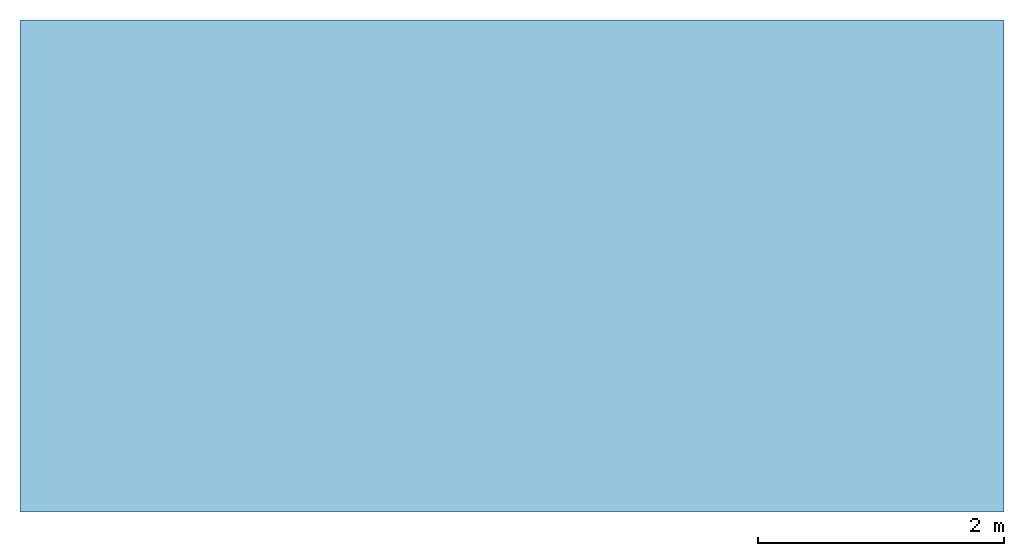
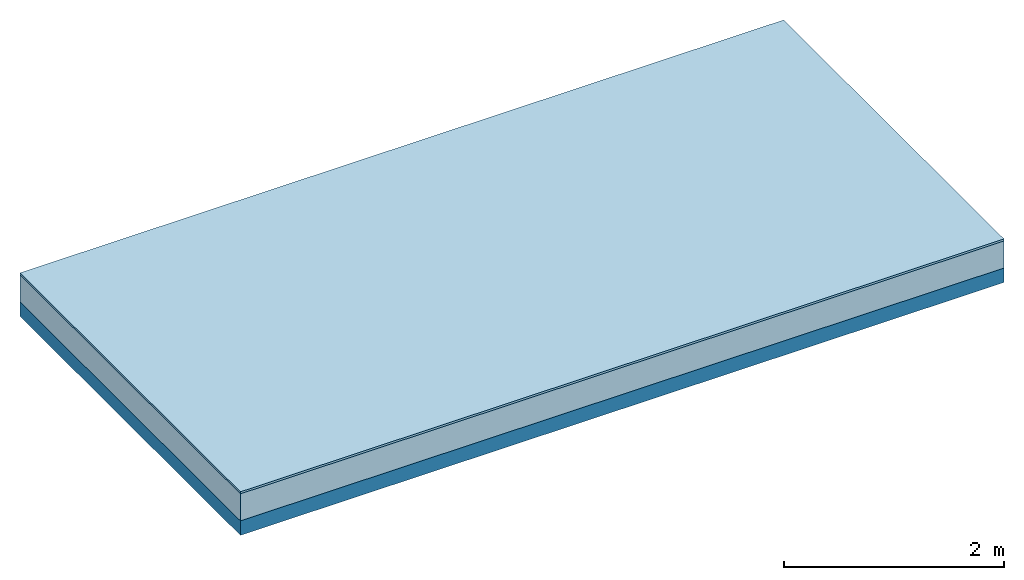
# One storey: 2 plates, 1 member, 1 element without a shape of its own.
"""IFC4 building model written with IfcOpenShell, lengths in metres."""

from ifc_helpers import new_model, si_unit, derived_unit, direction, frame, frame_2d, origin, origin_with_axes, place, context, project, spatial, rectangle, extrude, material, layer, layer_set, type_object, element, aggregate, save


model = new_model("IFC4")

# Units and contexts
plan_context = context("Plan", 3, precision=1e-05, world=origin(), true_north=direction((0.0, 1.0)))
model_context = context("Model", 3, precision=1e-05, world=origin(), true_north=direction((0.0, 1.0)))
ifc_project = project(units=[si_unit("LENGTHUNIT", "METRE"), derived_unit("SOUNDPRESSUREUNIT", [(si_unit("PRESSUREUNIT", "PASCAL", prefix="MICRO"), 0)]), si_unit("ENERGYUNIT", "JOULE", prefix="MEGA"), si_unit("MASSUNIT", "GRAM", prefix="KILO"), derived_unit("THERMALTRANSMITTANCEUNIT", [(si_unit("POWERUNIT", "WATT"), 1), (si_unit("AREAUNIT", "SQUARE_METRE"), -1), (si_unit("THERMODYNAMICTEMPERATUREUNIT", "KELVIN"), -1)]), derived_unit("AREADENSITYUNIT", [(si_unit("MASSUNIT", "GRAM", prefix="KILO"), 1), (si_unit("AREAUNIT", "SQUARE_METRE"), -1)]), derived_unit("USERDEFINED", [(si_unit("ENERGYUNIT", "JOULE", prefix="MEGA"), 1), (si_unit("AREAUNIT", "SQUARE_METRE"), -1)])], contexts=[plan_context, model_context])

# Site, building, storey
site = spatial("IfcSite", under=ifc_project)
building_placement = place(None, origin())
building = spatial("IfcBuilding", under=site, at=building_placement)
storey_placement = place(building_placement, origin())
storey = spatial("IfcBuildingStorey", under=building, at=storey_placement)

# Slab, member, plates
ifc_material_1 = material(Name="OSB3 panel", Category="07.013")
ifc_layer_1 = layer(ifc_material_1, 0.022, Name="On-material")
ifc_material_2 = material()
ifc_layer_2 = layer(ifc_material_2, 0.3, Name="Impact sound insulation")
ifc_material_3 = material(Name="no composite action")
ifc_layer_3 = layer(ifc_material_3, 0.0, Name="Bond")
ifc_layer_4 = layer(None, 0.16, Name="Supporting structure")
ifc_layer_set = layer_set([ifc_layer_1, ifc_layer_2, ifc_layer_3, ifc_layer_4])
slab_type = type_object("IfcSlabType", Name="A2179", PredefinedType="NOTDEFINED", material=ifc_layer_set)
slab_placement = place(None, frame((0.0, 0.0, 0.0), z_axis=(0.0, 0.0, -1.0), x_axis=(1.0, 0.0, 0.0)))
slab = element("IfcSlab", 1, at=slab_placement, inside=storey, type_object=slab_type, material=ifc_layer_set, Name="Slab #1")
ifc_material_4 = material(Name="Solid timber panel")
member_placement = place(slab_placement, origin())
member = element("IfcMember", 2, at=member_placement, material=ifc_material_4, Name="Supporting structure", context=plan_context, shape_type="SweptSolid", body=[
    extrude(rectangle(XDim=1.0, YDim=0.16, at=frame_2d((0.5, 0.08), x_axis=(1.0, 0.0))), frame((0.0, 4.0, 0.322), z_axis=(0.0, -1.0, 0.0), x_axis=(1.0, 0.0, 0.0)), (0.0, 0.0, 1.0), 4.0),
    extrude(rectangle(XDim=1.0, YDim=0.16, at=frame_2d((0.5, 0.08), x_axis=(1.0, 0.0))), frame((1.0, 4.0, 0.322), z_axis=(0.0, -1.0, 0.0), x_axis=(1.0, 0.0, 0.0)), (0.0, 0.0, 1.0), 4.0),
    extrude(rectangle(XDim=1.0, YDim=0.16, at=frame_2d((0.5, 0.08), x_axis=(1.0, 0.0))), frame((2.0, 4.0, 0.322), z_axis=(0.0, -1.0, 0.0), x_axis=(1.0, 0.0, 0.0)), (0.0, 0.0, 1.0), 4.0),
    extrude(rectangle(XDim=1.0, YDim=0.16, at=frame_2d((0.5, 0.08), x_axis=(1.0, 0.0))), frame((3.0, 4.0, 0.322), z_axis=(0.0, -1.0, 0.0), x_axis=(1.0, 0.0, 0.0)), (0.0, 0.0, 1.0), 4.0),
    extrude(rectangle(XDim=1.0, YDim=0.16, at=frame_2d((0.5, 0.08), x_axis=(1.0, 0.0))), frame((4.0, 4.0, 0.322), z_axis=(0.0, -1.0, 0.0), x_axis=(1.0, 0.0, 0.0)), (0.0, 0.0, 1.0), 4.0),
    extrude(rectangle(XDim=1.0, YDim=0.16, at=frame_2d((0.5, 0.08), x_axis=(1.0, 0.0))), frame((5.0, 4.0, 0.322), z_axis=(0.0, -1.0, 0.0), x_axis=(1.0, 0.0, 0.0)), (0.0, 0.0, 1.0), 4.0),
    extrude(rectangle(XDim=1.0, YDim=0.16, at=frame_2d((0.5, 0.08), x_axis=(1.0, 0.0))), frame((6.0, 4.0, 0.322), z_axis=(0.0, -1.0, 0.0), x_axis=(1.0, 0.0, 0.0)), (0.0, 0.0, 1.0), 4.0),
    extrude(rectangle(XDim=1.0, YDim=0.16, at=frame_2d((0.5, 0.08), x_axis=(1.0, 0.0))), frame((7.0, 4.0, 0.322), z_axis=(0.0, -1.0, 0.0), x_axis=(1.0, 0.0, 0.0)), (0.0, 0.0, 1.0), 4.0),
])
plate_1_placement = place(slab_placement, origin())
plate_1 = element("IfcPlate", 3, at=plate_1_placement, material=ifc_material_1, Name="On-material", context=plan_context, shape_type="SweptSolid", body=[
    extrude(rectangle(XDim=8.0, YDim=4.0, at=frame_2d((4.0, 2.0), x_axis=(1.0, 0.0))), origin_with_axes(), (0.0, 0.0, 1.0), 0.022),
])
plate_2_placement = place(slab_placement, origin())
plate_2 = element("IfcPlate", 4, at=plate_2_placement, material=ifc_material_2, Name="Impact sound insulation", context=plan_context, shape_type="SweptSolid", body=[
    extrude(rectangle(XDim=8.0, YDim=4.0, at=frame_2d((4.0, 2.0), x_axis=(1.0, 0.0))), frame((0.0, 0.0, 0.022), z_axis=(0.0, 0.0, 1.0), x_axis=(1.0, 0.0, 0.0)), (0.0, 0.0, 1.0), 0.3),
])
aggregate(slab, [plate_1, plate_2, member])

save(model, "model.ifc")
